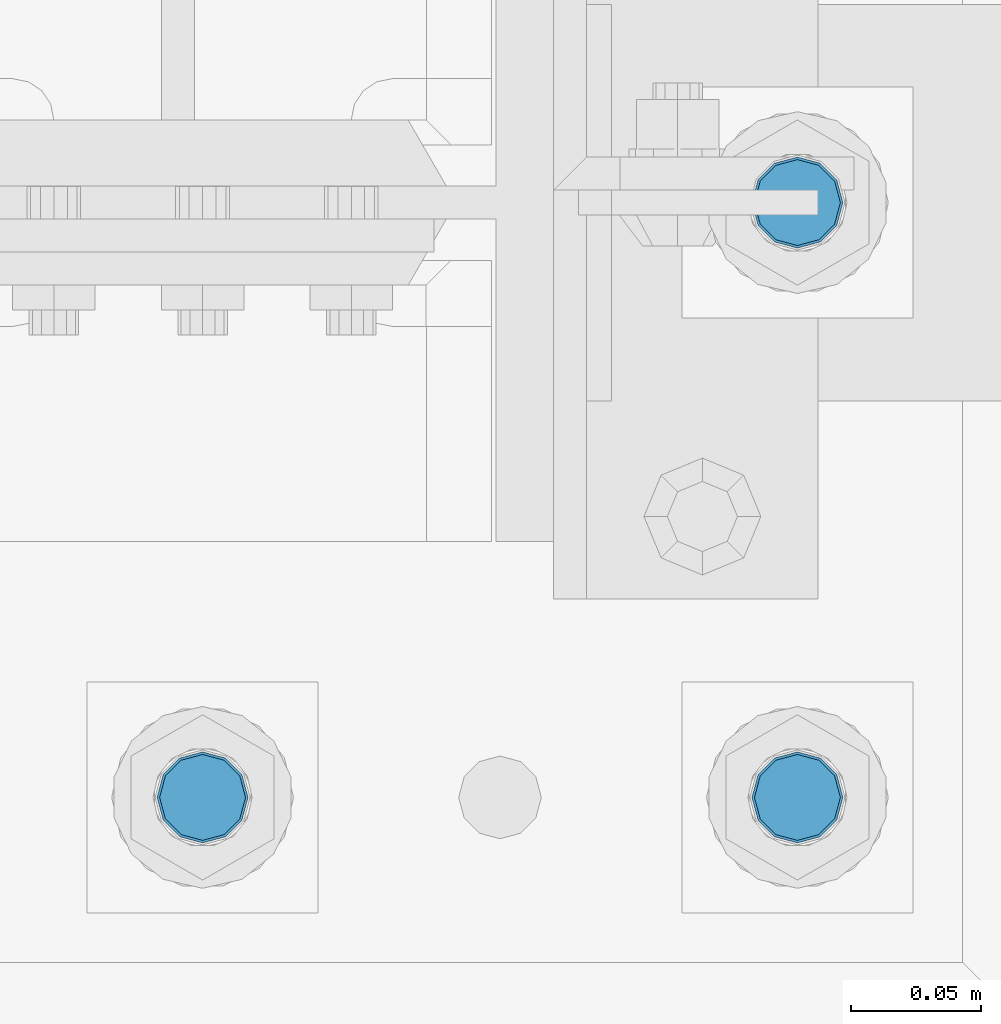
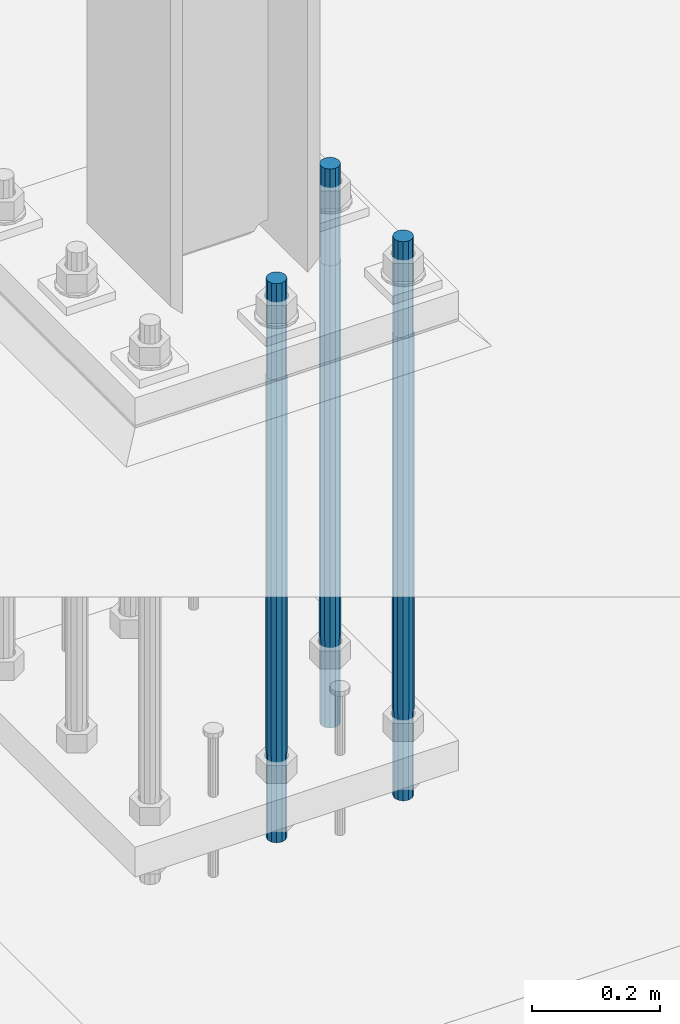
# One storey, part 569 of 1876: 3 columns, 1 element without a shape of its own.
"""IFC2X3 building model written with IfcOpenShell, lengths in millimetres."""

from ifc_helpers import new_model, si_unit, frame, origin_with_axes, place, context, subcontext, project, spatial, faceted_brep, material, type_object, element, aggregate, save


model = new_model("IFC2X3")

# Units and contexts
model_context = context("Model", 3, precision=1e-05, world=origin_with_axes())
body_context = subcontext(model_context, "Body", "Model", "MODEL_VIEW")
ifc_project = project(units=[si_unit("LENGTHUNIT", "METRE", prefix="MILLI"), si_unit("AREAUNIT", "SQUARE_METRE"), si_unit("VOLUMEUNIT", "CUBIC_METRE"), si_unit("MASSUNIT", "GRAM", prefix="KILO"), si_unit("TIMEUNIT", "SECOND"), si_unit("PLANEANGLEUNIT", "RADIAN"), si_unit("SOLIDANGLEUNIT", "STERADIAN"), si_unit("THERMODYNAMICTEMPERATUREUNIT", "DEGREE_CELSIUS"), si_unit("LUMINOUSINTENSITYUNIT", "LUMEN")], contexts=[model_context])

# Site, building, storey
site_placement = place(None, origin_with_axes())
site = spatial("IfcSite", under=ifc_project, at=site_placement, CompositionType="ELEMENT")
building_placement = place(site_placement, origin_with_axes())
building = spatial("IfcBuilding", under=site, at=building_placement, Name="Undefined", CompositionType="ELEMENT")
storey_placement = place(building_placement, origin_with_axes())
storey = spatial("IfcBuildingStorey", under=building, at=storey_placement, Name="Undefined", CompositionType="ELEMENT", Elevation=0.0)

# Assembly, columns
assembly_placement = place(storey_placement, origin_with_axes())
assembly = element("IfcElementAssembly", 1, at=assembly_placement, inside=storey, Name="TEMPLATE", AssemblyPlace="NOTDEFINED", PredefinedType="RIGID_FRAME")
ifc_material = material(Name="STEEL/F1554-GR.105")
column_type = type_object("IfcColumnType", PredefinedType="NOTDEFINED")
column_1_placement = place(assembly_placement, frame((1955.8, -7340.6, 0.0), z_axis=(1.0, 0.0, 0.0), x_axis=(0.0, 0.0, -1.0)))
column_1 = element("IfcColumn", 2, at=column_1_placement, type_object=column_type, material=ifc_material, Name="ANCHOR_BOLTS", context=body_context, shape_type="Brep", body=[
    faceted_brep([(-184.15, -14.2894191624437, 8.25), (-184.15, -8.25, 14.2894191624432), (-184.15, 0.0, 16.5), (-184.15, 8.25, 14.2894191624432), (-184.15, 14.2894191624437, 8.25), (-184.15, 16.5, 0.0), (-184.15, 14.2894191624437, -8.25), (-184.15, 8.25, -14.2894191624432), (-184.15, 0.0, -16.5), (-184.15, -8.25, -14.2894191624432), (-184.15, -14.2894191624437, -8.25), (-184.15, -16.5, 0.0), (0.0, 16.5, 0.0), (0.0, 14.2894191624437, -8.25), (0.0, 8.25, -14.2894191624432), (0.0, 0.0, -16.5), (0.0, -8.25, -14.2894191624432), (0.0, -14.2894191624437, -8.25), (0.0, -16.5, 0.0), (0.0, -14.2894191624437, 8.25), (0.0, -8.25, 14.2894191624432), (0.0, 0.0, 16.5), (0.0, 8.25, 14.2894191624432), (0.0, 14.2894191624437, 8.25), (0.0, -15.1229686135858, 8.73125000000073), (0.0, -8.73124999999999, 15.1229686135848), (0.0, 0.0, 17.4625000000015), (0.0, 8.73124999999999, 15.1229686135848), (0.0, 15.1229686135858, 8.73125000000073), (0.0, 17.4625, 0.0), (0.0, 15.1229686135858, -8.73125000000073), (0.0, 8.73124999999999, -15.1229686135848), (0.0, 0.0, -17.4625000000015), (0.0, -8.73124999999999, -15.1229686135848), (0.0, -15.1229686135857, -8.73125000000073), (0.0, -17.4625, 0.0), (717.55, -17.4624999999996, 0.0), (717.55, -15.1229686135857, 8.73125000000005), (717.55, -8.73124999999982, 15.1229686135857), (717.55, 0.0, 17.4625000000001), (717.55, 8.73124999999982, 15.1229686135857), (717.55, 15.1229686135857, 8.73125000000005), (717.55, 17.4624999999996, 0.0), (717.55, 15.1229686135857, -8.73125000000005), (717.55, 8.73124999999982, -15.1229686135857), (717.55, 0.0, -17.4625000000001), (717.55, -8.73124999999982, -15.1229686135857), (717.55, -15.1229686135857, -8.73125000000005), (717.55, -8.25, 14.2894191624432), (717.55, 0.0, 16.5), (717.55, 8.25, 14.2894191624432), (717.55, 14.2894191624437, 8.25), (717.55, 16.5, 0.0), (717.55, 14.2894191624437, -8.25), (717.55, 8.25, -14.2894191624432), (717.55, 0.0, -16.5), (717.55, -8.25, -14.2894191624432), (717.55, -14.2894191624437, -8.25), (717.55, -16.5, 0.0), (717.55, -14.2894191624437, 8.25), (882.65, -8.25, -14.2894191624432), (882.65, 0.0, -16.5), (882.65, 8.25, -14.2894191624432), (882.65, 14.2894191624437, -8.25), (882.65, 16.5, 0.0), (882.65, 14.2894191624437, 8.25), (882.65, 8.25, 14.2894191624432), (882.65, 0.0, 16.5), (882.65, -8.25, 14.2894191624432), (882.65, -14.2894191624437, 8.25), (882.65, -16.5, 0.0), (882.65, -14.2894191624437, -8.25)], [[[0, 1, 2, 3, 4, 5, 6, 7, 8, 9, 10, 11]], [[6, 5, 12, 13]], [[7, 6, 13, 14]], [[8, 7, 14, 15]], [[9, 8, 15, 16]], [[10, 9, 16, 17]], [[11, 10, 17, 18]], [[0, 11, 18, 19]], [[1, 0, 19, 20]], [[2, 1, 20, 21]], [[3, 2, 21, 22]], [[4, 3, 22, 23]], [[5, 4, 23, 12]], [[24, 25, 26, 27, 28, 29, 30, 31, 32, 33, 34, 35], [22, 21, 20, 19, 18, 17, 16, 15, 14, 13, 12, 23]], [[24, 35, 36, 37]], [[25, 24, 37, 38]], [[26, 25, 38, 39]], [[27, 26, 39, 40]], [[28, 27, 40, 41]], [[29, 28, 41, 42]], [[30, 29, 42, 43]], [[31, 30, 43, 44]], [[32, 31, 44, 45]], [[33, 32, 45, 46]], [[34, 33, 46, 47]], [[35, 34, 47, 36]], [[46, 45, 44, 43, 42, 41, 40, 39, 38, 37, 36, 47], [48, 49, 50, 51, 52, 53, 54, 55, 56, 57, 58, 59]], [[60, 61, 62, 63, 64, 65, 66, 67, 68, 69, 70, 71]], [[68, 67, 49, 48]], [[69, 68, 48, 59]], [[70, 69, 59, 58]], [[71, 70, 58, 57]], [[60, 71, 57, 56]], [[61, 60, 56, 55]], [[62, 61, 55, 54]], [[63, 62, 54, 53]], [[64, 63, 53, 52]], [[65, 64, 52, 51]], [[66, 65, 51, 50]], [[67, 66, 50, 49]]]),
])
column_2_placement = place(assembly_placement, frame((1955.8, -7112.0, 0.0), z_axis=(1.0, 0.0, 0.0), x_axis=(0.0, 0.0, -1.0)))
column_2 = element("IfcColumn", 3, at=column_2_placement, type_object=column_type, material=ifc_material, Name="ANCHOR_BOLTS", context=body_context, shape_type="Brep", body=[
    faceted_brep([(-184.15, -14.2894191624437, 8.25), (-184.15, -8.25, 14.2894191624432), (-184.15, 0.0, 16.5), (-184.15, 8.25, 14.2894191624432), (-184.15, 14.2894191624437, 8.25), (-184.15, 16.5, 0.0), (-184.15, 14.2894191624437, -8.25), (-184.15, 8.25, -14.2894191624432), (-184.15, 0.0, -16.5), (-184.15, -8.25, -14.2894191624432), (-184.15, -14.2894191624437, -8.25), (-184.15, -16.5, 0.0), (0.0, 16.5, 0.0), (0.0, 14.2894191624437, -8.25), (0.0, 8.25, -14.2894191624432), (0.0, 0.0, -16.5), (0.0, -8.25, -14.2894191624432), (0.0, -14.2894191624437, -8.25), (0.0, -16.5, 0.0), (0.0, -14.2894191624437, 8.25), (0.0, -8.25, 14.2894191624432), (0.0, 0.0, 16.5), (0.0, 8.25, 14.2894191624432), (0.0, 14.2894191624437, 8.25), (0.0, -15.1229686135858, 8.73125000000073), (0.0, -8.73124999999999, 15.1229686135848), (0.0, 0.0, 17.4625000000015), (0.0, 8.73124999999999, 15.1229686135848), (0.0, 15.1229686135858, 8.73125000000073), (0.0, 17.4625, 0.0), (0.0, 15.1229686135858, -8.73125000000073), (0.0, 8.73124999999999, -15.1229686135848), (0.0, 0.0, -17.4625000000015), (0.0, -8.73124999999999, -15.1229686135848), (0.0, -15.1229686135857, -8.73125000000073), (0.0, -17.4625, 0.0), (717.55, -17.4624999999996, 0.0), (717.55, -15.1229686135857, 8.73125000000005), (717.55, -8.73124999999982, 15.1229686135857), (717.55, 0.0, 17.4625000000001), (717.55, 8.73124999999982, 15.1229686135857), (717.55, 15.1229686135857, 8.73125000000005), (717.55, 17.4624999999996, 0.0), (717.55, 15.1229686135857, -8.73125000000005), (717.55, 8.73124999999982, -15.1229686135857), (717.55, 0.0, -17.4625000000001), (717.55, -8.73124999999982, -15.1229686135857), (717.55, -15.1229686135857, -8.73125000000005), (717.55, -8.25, 14.2894191624432), (717.55, 0.0, 16.5), (717.55, 8.25, 14.2894191624432), (717.55, 14.2894191624437, 8.25), (717.55, 16.5, 0.0), (717.55, 14.2894191624437, -8.25), (717.55, 8.25, -14.2894191624432), (717.55, 0.0, -16.5), (717.55, -8.25, -14.2894191624432), (717.55, -14.2894191624437, -8.25), (717.55, -16.5, 0.0), (717.55, -14.2894191624437, 8.25), (882.65, -8.25, -14.2894191624432), (882.65, 0.0, -16.5), (882.65, 8.25, -14.2894191624432), (882.65, 14.2894191624437, -8.25), (882.65, 16.5, 0.0), (882.65, 14.2894191624437, 8.25), (882.65, 8.25, 14.2894191624432), (882.65, 0.0, 16.5), (882.65, -8.25, 14.2894191624432), (882.65, -14.2894191624437, 8.25), (882.65, -16.5, 0.0), (882.65, -14.2894191624437, -8.25)], [[[0, 1, 2, 3, 4, 5, 6, 7, 8, 9, 10, 11]], [[6, 5, 12, 13]], [[7, 6, 13, 14]], [[8, 7, 14, 15]], [[9, 8, 15, 16]], [[10, 9, 16, 17]], [[11, 10, 17, 18]], [[0, 11, 18, 19]], [[1, 0, 19, 20]], [[2, 1, 20, 21]], [[3, 2, 21, 22]], [[4, 3, 22, 23]], [[5, 4, 23, 12]], [[24, 25, 26, 27, 28, 29, 30, 31, 32, 33, 34, 35], [22, 21, 20, 19, 18, 17, 16, 15, 14, 13, 12, 23]], [[24, 35, 36, 37]], [[25, 24, 37, 38]], [[26, 25, 38, 39]], [[27, 26, 39, 40]], [[28, 27, 40, 41]], [[29, 28, 41, 42]], [[30, 29, 42, 43]], [[31, 30, 43, 44]], [[32, 31, 44, 45]], [[33, 32, 45, 46]], [[34, 33, 46, 47]], [[35, 34, 47, 36]], [[46, 45, 44, 43, 42, 41, 40, 39, 38, 37, 36, 47], [48, 49, 50, 51, 52, 53, 54, 55, 56, 57, 58, 59]], [[60, 61, 62, 63, 64, 65, 66, 67, 68, 69, 70, 71]], [[68, 67, 49, 48]], [[69, 68, 48, 59]], [[70, 69, 59, 58]], [[71, 70, 58, 57]], [[60, 71, 57, 56]], [[61, 60, 56, 55]], [[62, 61, 55, 54]], [[63, 62, 54, 53]], [[64, 63, 53, 52]], [[65, 64, 52, 51]], [[66, 65, 51, 50]], [[67, 66, 50, 49]]]),
])
column_3_placement = place(assembly_placement, frame((1727.2, -7340.6, 0.0), z_axis=(1.0, 0.0, 0.0), x_axis=(0.0, 0.0, -1.0)))
column_3 = element("IfcColumn", 4, at=column_3_placement, type_object=column_type, material=ifc_material, Name="ANCHOR_BOLTS", context=body_context, shape_type="Brep", body=[
    faceted_brep([(-184.15, -14.2894191624437, 8.25), (-184.15, -8.25, 14.2894191624432), (-184.15, 0.0, 16.5), (-184.15, 8.25, 14.2894191624432), (-184.15, 14.2894191624437, 8.25), (-184.15, 16.5, 0.0), (-184.15, 14.2894191624437, -8.25), (-184.15, 8.25, -14.2894191624432), (-184.15, 0.0, -16.5), (-184.15, -8.25, -14.2894191624432), (-184.15, -14.2894191624437, -8.25), (-184.15, -16.5, 0.0), (0.0, 16.5, 0.0), (0.0, 14.2894191624437, -8.25), (0.0, 8.25, -14.2894191624432), (0.0, 0.0, -16.5), (0.0, -8.25, -14.2894191624432), (0.0, -14.2894191624437, -8.25), (0.0, -16.5, 0.0), (0.0, -14.2894191624437, 8.25), (0.0, -8.25, 14.2894191624432), (0.0, 0.0, 16.5), (0.0, 8.25, 14.2894191624432), (0.0, 14.2894191624437, 8.25), (0.0, -15.1229686135858, 8.73125000000073), (0.0, -8.73124999999999, 15.1229686135848), (0.0, 0.0, 17.4625000000015), (0.0, 8.73124999999999, 15.1229686135848), (0.0, 15.1229686135858, 8.73125000000073), (0.0, 17.4625, 0.0), (0.0, 15.1229686135858, -8.73125000000073), (0.0, 8.73124999999999, -15.1229686135848), (0.0, 0.0, -17.4625000000015), (0.0, -8.73124999999999, -15.1229686135848), (0.0, -15.1229686135857, -8.73125000000073), (0.0, -17.4625, 0.0), (717.55, -17.4624999999996, 0.0), (717.55, -15.1229686135857, 8.73125000000005), (717.55, -8.73124999999982, 15.1229686135857), (717.55, 0.0, 17.4625000000001), (717.55, 8.73124999999982, 15.1229686135857), (717.55, 15.1229686135857, 8.73125000000005), (717.55, 17.4624999999996, 0.0), (717.55, 15.1229686135857, -8.73125000000005), (717.55, 8.73124999999982, -15.1229686135857), (717.55, 0.0, -17.4625000000001), (717.55, -8.73124999999982, -15.1229686135857), (717.55, -15.1229686135857, -8.73125000000005), (717.55, -8.25, 14.2894191624432), (717.55, 0.0, 16.5), (717.55, 8.25, 14.2894191624432), (717.55, 14.2894191624437, 8.25), (717.55, 16.5, 0.0), (717.55, 14.2894191624437, -8.25), (717.55, 8.25, -14.2894191624432), (717.55, 0.0, -16.5), (717.55, -8.25, -14.2894191624432), (717.55, -14.2894191624437, -8.25), (717.55, -16.5, 0.0), (717.55, -14.2894191624437, 8.25), (882.65, -8.25, -14.2894191624432), (882.65, 0.0, -16.5), (882.65, 8.25, -14.2894191624432), (882.65, 14.2894191624437, -8.25), (882.65, 16.5, 0.0), (882.65, 14.2894191624437, 8.25), (882.65, 8.25, 14.2894191624432), (882.65, 0.0, 16.5), (882.65, -8.25, 14.2894191624432), (882.65, -14.2894191624437, 8.25), (882.65, -16.5, 0.0), (882.65, -14.2894191624437, -8.25)], [[[0, 1, 2, 3, 4, 5, 6, 7, 8, 9, 10, 11]], [[6, 5, 12, 13]], [[7, 6, 13, 14]], [[8, 7, 14, 15]], [[9, 8, 15, 16]], [[10, 9, 16, 17]], [[11, 10, 17, 18]], [[0, 11, 18, 19]], [[1, 0, 19, 20]], [[2, 1, 20, 21]], [[3, 2, 21, 22]], [[4, 3, 22, 23]], [[5, 4, 23, 12]], [[24, 25, 26, 27, 28, 29, 30, 31, 32, 33, 34, 35], [22, 21, 20, 19, 18, 17, 16, 15, 14, 13, 12, 23]], [[24, 35, 36, 37]], [[25, 24, 37, 38]], [[26, 25, 38, 39]], [[27, 26, 39, 40]], [[28, 27, 40, 41]], [[29, 28, 41, 42]], [[30, 29, 42, 43]], [[31, 30, 43, 44]], [[32, 31, 44, 45]], [[33, 32, 45, 46]], [[34, 33, 46, 47]], [[35, 34, 47, 36]], [[46, 45, 44, 43, 42, 41, 40, 39, 38, 37, 36, 47], [48, 49, 50, 51, 52, 53, 54, 55, 56, 57, 58, 59]], [[60, 61, 62, 63, 64, 65, 66, 67, 68, 69, 70, 71]], [[68, 67, 49, 48]], [[69, 68, 48, 59]], [[70, 69, 59, 58]], [[71, 70, 58, 57]], [[60, 71, 57, 56]], [[61, 60, 56, 55]], [[62, 61, 55, 54]], [[63, 62, 54, 53]], [[64, 63, 53, 52]], [[65, 64, 52, 51]], [[66, 65, 51, 50]], [[67, 66, 50, 49]]]),
])
aggregate(assembly, [column_1, column_2, column_3])

save(model, "model.ifc")
